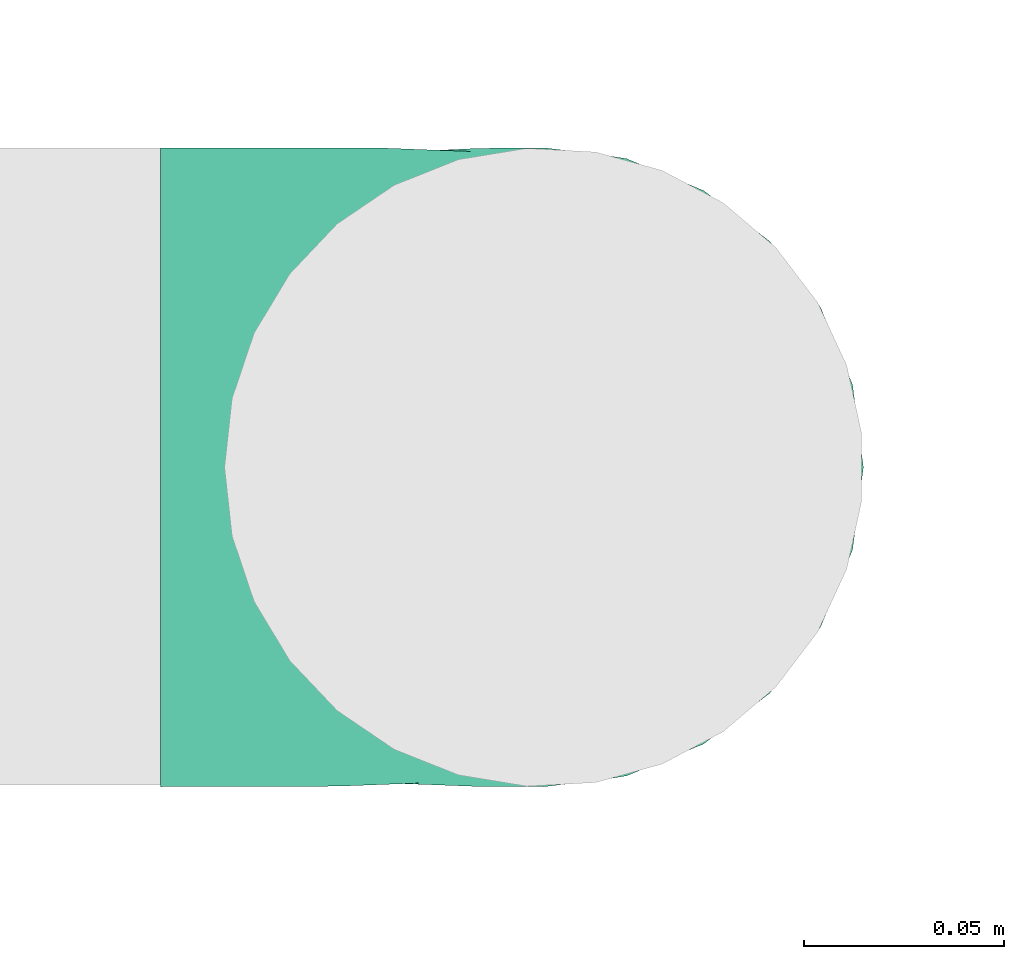
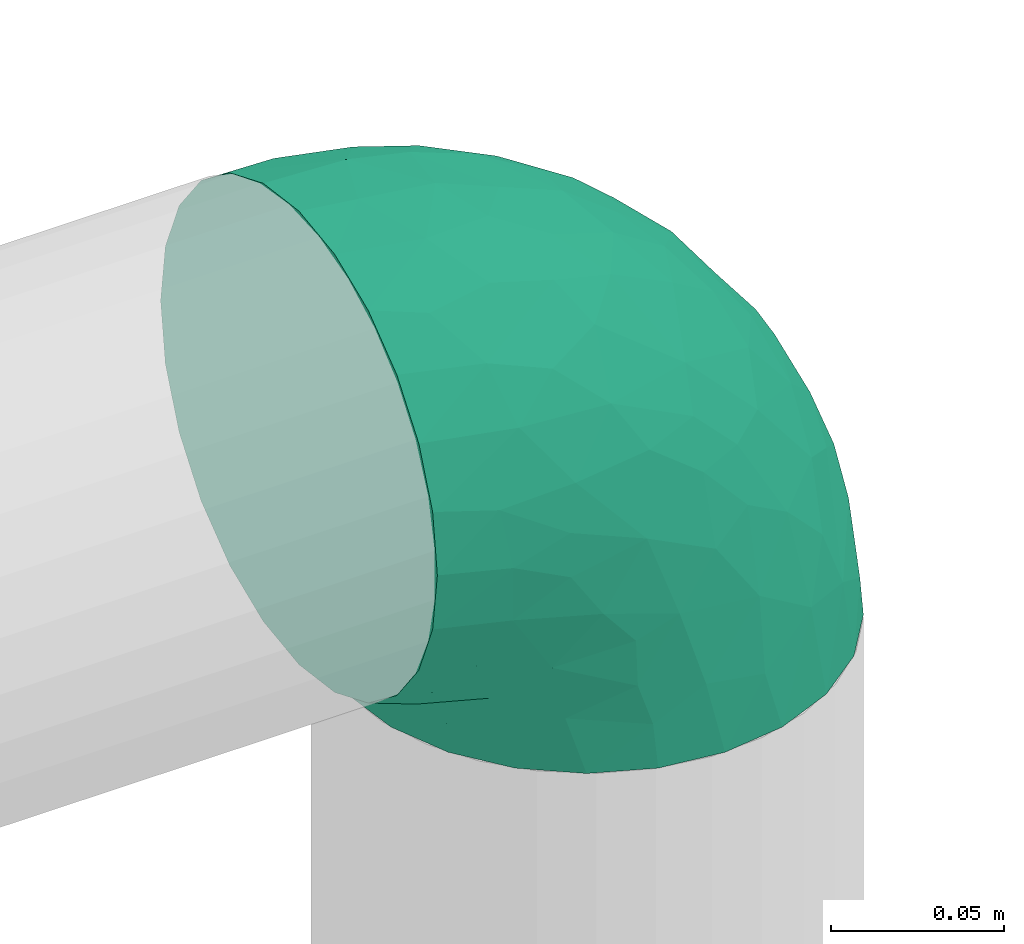
# One storey, part 3 of 12: 1 flow fitting.
"""IFC2X3 building model written with IfcOpenShell, lengths in millimetres."""

from ifc_helpers import new_model, entity, si_unit, converted_unit, derived_unit, direction, frame, origin, place, context, subcontext, project, spatial, faceted_brep, source, transform, mapped, type_object, type_shapes, element, save


model = new_model("IFC2X3")

# Units and contexts
model_context = context("Model", 3, precision=0.01, world=origin(), true_north=direction((6.12303176911189e-17, 1.0)))
body_context = subcontext(model_context, "Body", "Model", "MODEL_VIEW")
ifc_project = project(units=[si_unit("LENGTHUNIT", "METRE", prefix="MILLI"), si_unit("AREAUNIT", "SQUARE_METRE"), si_unit("VOLUMEUNIT", "CUBIC_METRE"), converted_unit("PLANEANGLEUNIT", "DEGREE", entity("IfcRatioMeasure", 0.0174532925199433), si_unit("PLANEANGLEUNIT", "RADIAN"), dimensions=[0, 0, 0, 0, 0, 0, 0]), si_unit("MASSUNIT", "GRAM", prefix="KILO"), derived_unit("MASSDENSITYUNIT", [(si_unit("MASSUNIT", "GRAM", prefix="KILO"), 1), (si_unit("LENGTHUNIT", "METRE"), -3)]), si_unit("TIMEUNIT", "SECOND"), si_unit("FREQUENCYUNIT", "HERTZ"), si_unit("THERMODYNAMICTEMPERATUREUNIT", "DEGREE_CELSIUS"), derived_unit("THERMALTRANSMITTANCEUNIT", [(si_unit("MASSUNIT", "GRAM", prefix="KILO"), 1), (si_unit("THERMODYNAMICTEMPERATUREUNIT", "KELVIN"), -1), (si_unit("TIMEUNIT", "SECOND"), -3)]), derived_unit("VOLUMETRICFLOWRATEUNIT", [(si_unit("LENGTHUNIT", "METRE"), 3), (si_unit("TIMEUNIT", "SECOND"), -1)]), si_unit("ELECTRICCURRENTUNIT", "AMPERE"), si_unit("ELECTRICVOLTAGEUNIT", "VOLT"), si_unit("POWERUNIT", "WATT"), si_unit("FORCEUNIT", "NEWTON", prefix="KILO"), si_unit("ILLUMINANCEUNIT", "LUX"), si_unit("LUMINOUSFLUXUNIT", "LUMEN"), si_unit("LUMINOUSINTENSITYUNIT", "CANDELA"), derived_unit("USERDEFINED", [(si_unit("MASSUNIT", "GRAM", prefix="KILO"), -1), (si_unit("LENGTHUNIT", "METRE"), -2), (si_unit("TIMEUNIT", "SECOND"), 3), (si_unit("LUMINOUSFLUXUNIT", "LUMEN"), 1)]), derived_unit("LINEARVELOCITYUNIT", [(si_unit("LENGTHUNIT", "METRE"), 1), (si_unit("TIMEUNIT", "SECOND"), -1)]), si_unit("PRESSUREUNIT", "PASCAL"), derived_unit("USERDEFINED", [(si_unit("LENGTHUNIT", "METRE"), -2), (si_unit("MASSUNIT", "GRAM", prefix="KILO"), 1), (si_unit("TIMEUNIT", "SECOND"), -2)])], contexts=[model_context])

# Site, building, storey
site_placement = place(None, origin())
site = spatial("IfcSite", under=ifc_project, at=site_placement, CompositionType="ELEMENT")
building_placement = place(site_placement, origin())
building = spatial("IfcBuilding", under=site, at=building_placement, CompositionType="ELEMENT")
storey_placement = place(building_placement, frame((0.0, 0.0, 8000.0)))
storey = spatial("IfcBuildingStorey", under=building, at=storey_placement, Name="02 Level", CompositionType="ELEMENT", Elevation=8000.0)

# Flow fitting
duct_fitting_type = type_object("IfcDuctFittingType", Name="Air_Elbow short_Circ", PredefinedType="NOTDEFINED")
shared_shape = source(origin(), body_context, "Body", "Brep", [
    faceted_brep([(-96.0, 40.0, -69.2820323027551), (-96.0, 20.7055236082018, -77.2740661031254), (-96.0, 0.0, -80.0), (-96.0, -20.7055236082015, -77.2740661031255), (-96.0, -40.0, -69.2820323027552), (-96.0, -56.5685424949237, -56.5685424949239), (-96.0, -69.282032302755, -40.0), (-96.0, -77.2740661031254, -20.7055236082019), (-96.0, -80.0, 0.0), (-96.0, -77.2740661031256, 20.7055236082014), (-96.0, -69.2820323027553, 40.0), (-96.0, -56.568542494924, 56.5685424949236), (-96.0, -40.0, 69.2820323027549), (-96.0, -20.705523608202, 77.2740661031254), (-96.0, 0.0, 80.0), (-96.0, 20.7055236082013, 77.2740661031256), (-96.0, 30.3527618041005, 73.2780492029404), (-96.0, 40.0, 69.2820323027553), (-96.0, 56.5685424949235, 56.5685424949241), (-96.0, 69.2820323027549, 40.0), (-96.0, 77.2740661031253, 20.7055236082021), (-96.0, 80.0, 0.0), (-96.0, 77.2740661031255, -20.7055236082016), (-96.0, 69.2820323027551, -40.0), (-96.0, 56.5685424949239, -56.5685424949238), (0.0, 96.0, -80.0), (-20.7055236082008, 96.0, -77.2740661031254), (-30.3527618041, 96.0, -73.2780492029402), (-40.0, 96.0, -69.2820323027551), (-56.5685424949229, 96.0, -56.5685424949238), (-69.2820323027542, 96.0, -40.0), (-77.2740661031245, 96.0, -20.7055236082016), (-80.0, 96.0, 0.0), (-77.2740661031244, 96.0, 20.7055236082021), (-69.2820323027539, 96.0, 40.0), (-56.5685424949226, 96.0, 56.5685424949241), (-40.0, 96.0, 69.2820323027553), (-20.7055236082004, 96.0, 77.2740661031256), (0.0, 96.0, 80.0), (20.7055236082029, 96.0, 77.2740661031254), (40.0, 96.0, 69.2820323027549), (56.5685424949249, 96.0, 56.5685424949236), (69.2820323027562, 96.0, 40.0), (77.2740661031265, 96.0, 20.7055236082014), (80.0, 96.0, 0.0), (77.2740661031264, 96.0, -20.7055236082019), (69.2820323027559, 96.0, -40.0), (56.5685424949246, 96.0, -56.5685424949239), (40.0, 96.0, -69.2820323027552), (20.7055236082025, 96.0, -77.2740661031255), (-69.6571465232348, 6.28172173912476, 79.9611058756859), (-55.1380888291464, -64.4450584799279, 39.5029426177976), (-78.4902527850466, -65.2482264041437, 44.9229732355936), (-66.7862289407348, -74.1387210661139, 22.9795507758541), (-79.9123689128389, 22.4151301859584, 77.2816866630488), (-75.1250134759213, 46.3506195730757, 68.0011973810265), (-46.2820694578435, -43.7397705581167, 60.5188244193914), (-62.9760666105318, -34.5362195419601, 70.0448030595901), (-67.1316735243184, -51.7530432423058, 58.5204707533666), (-50.4478480619551, -74.0029454268759, 0.0), (-76.2276812833835, -77.3969248578635, 0.0), (-27.189372084162, 68.980536479128, 76.8941402015288), (-6.30632028234235, 70.6421404093778, 79.9513108199466), (-47.7584488981354, -13.6212410427434, 76.3881123659885), (-29.8609237116382, -28.9682345099716, 65.8760199345924), (57.6005967886466, 33.4719572927763, 39.0176496769077), (51.7530435574228, 67.1316742002235, 58.5204705859065), (43.7397637815864, 46.2820598522933, 60.518827155348), (-74.2591571701267, -14.3645886695287, 78.2829835259588), (28.4507934888335, -28.4507934888321, 0.0), (23.3846344985257, -27.9066135199674, 24.7887114209846), (7.8513563843086, -42.4938374080907, 21.3232874317503), (-84.190871651952, 70.905997349447, 41.7100461919055), (24.7272484782103, -2.06889411058577, 53.4325037134459), (-0.0180155578363953, -25.9284255475521, 53.836744023285), (10.21505333872, -32.0754161621096, 38.020212353501), (-64.5619855594544, 27.52018553659, 77.2892967298799), (-41.7574890626937, 15.123136403511, 79.988056483004), (-24.5336756868846, -60.9669573051438, 23.5003835585885), (-29.2239240309769, -65.2117082464685, 0.0), (-8.0, -56.420471066061, 0.0), (-16.4008295437786, 51.3122057461681, 79.8609584412684), (-83.0529092063249, 83.0529092103045, 19.0855009657076), (-84.6862915010143, 84.6862915010152, 0.0), (-82.4185651555764, 62.2587017800419, 53.3339952483838), (-46.3022193149449, 75.902750025661, 67.8445262622594), (-9.5260688639158, -47.7232209131232, 35.4187162694583), (74.1387213421635, 66.7862279048973, 22.9795492840646), (14.3645870599314, 74.259154996167, 78.2829837700474), (34.536215572589, 62.976064096567, 70.0448048426748), (65.2482273833467, 78.4902510979302, 44.9229715327465), (-12.3935655196116, 25.4017250572252, 78.8652642576962), (-25.6317751341749, 1.2640655514879, 76.9124052095498), (69.8186739706361, 42.5625104806759, 16.7980672722629), (64.4450597015273, 55.1380839274934, 39.5029384026545), (60.9669574479924, 24.5336725945725, 23.5003789659965), (77.3969247188647, 76.2276802275763, 0.0), (74.002945426877, 50.4478480619565, 0.0), (-66.5995156060253, 66.5995146556305, 58.6370817132137), (-52.4774893100348, 53.0631556360015, 72.0041598972686), (-76.4857465466113, 78.9385356944492, 38.5867538667356), (-62.2587016209511, 82.4185645906685, 53.3339956492136), (28.9682276847195, 29.8609133580269, 65.8760207540895), (13.6212369177471, 47.7584433090926, 76.3881128402526), (-6.49930484510329, -53.7890406240985, 15.4645725223014), (-33.731289034344, 40.0214486160993, 79.0537019298314), (46.1336936566893, 26.2441492635858, 50.151541479116), (42.4356322774479, -10.225396744416, 0.0), (56.4204710660622, 8.0, 0.0), (50.0005984633279, 1.26038287501495, 17.5763945268078), (-45.4536887619888, -68.8356359385787, 23.6914879663761), (-33.3493864711472, -57.4572215948989, 39.1720709545353), (35.9683398342664, -11.0724559744972, 30.5391080332169), (-26.2441652621668, -46.1336984778153, 50.1515448602929), (36.6749123583047, -17.5982116941791, 14.5644188861001), (65.2117082464696, 29.2239240309784, 0.0), (49.5968730216335, 12.1440064858134, 34.8325942562253), (-47.1533280807863, 29.0746114834461, 78.9127210009486), (-0.981722938535007, 51.3162880079176, 79.4920802366619), (12.4951682569875, 20.0804783439543, 71.2292489374933), (-1.95170750213435, 1.95169859379814, 70.9272590604952), (13.0725391330592, 1.13338064801589, 63.5790506070627), (-1.93327092594732, -13.4823821925323, 63.7412032706882), (-18.9298205951927, -13.0048872663631, 70.6672094580024), (10.2253967444173, -42.4356322774466, 0.0), (-68.9805369123341, 27.1893702897943, -76.8941406355589), (-22.4151342180024, 79.9123577737124, -77.2816862456941), (-27.5201921618733, 64.5619784506715, -77.2892959136582), (-46.3506180288022, 75.1250185023919, -68.0011970559212), (-74.2591561090454, -14.364589592643, -78.2829832920378), (-42.5625109127564, -69.8186736490614, -16.7980693145318), (-66.78622820047, -74.1387209331735, -22.9795507950237), (-70.6421421271429, 6.30631801763141, -79.9513108797024), (-25.401718902627, 12.3935649209934, -78.8652635038296), (-15.1231475192353, 41.7574898106582, -79.9880566497423), (-1.2640784754681, 25.6317655571971, -76.9124065444174), (-78.9385361639639, 76.4857467527193, -38.5867530236755), (-66.5995166501766, 66.5995137008527, -58.6370816545605), (-82.4185656924104, 62.258701559575, -53.3339952529289), (60.9669567069012, 24.5336743104721, -23.5003834743896), (53.7890400497189, 6.49930371043273, -15.4645720709197), (-55.1380878256228, -64.4450583029017, -39.5029424837467), (-24.5336751436549, -60.9669572920351, -23.5003828649414), (-29.8609212227281, -28.9682353164184, -65.8760186412515), (-26.2441631797834, -46.1336980827234, -50.1515441608816), (-46.2820677406335, -43.7397707662098, -60.5188237522514), (74.1387206827049, 66.7862275406284, -22.9795512458422), (-40.0214489824224, 33.7312845774564, -79.0537024061946), (-78.4902524468744, -65.2482264004152, -44.9229731872606), (-75.902751427461, 46.3022186029078, -67.8445263463497), (-70.9059970555813, 84.1908706304995, -41.7100473389448), (-67.1316724627346, -51.7530434014037, -58.5204704180807), (-62.9760652707231, -34.536220162299, -70.044802546446), (-33.4719630839568, -57.6005950429912, -39.0176564793206), (-51.3122062597491, 16.4008248291117, -79.8609586691244), (-6.28171714934502, 69.65712797409, -79.9611061760713), (51.7530427306645, 67.1316703492073, -58.5204706539109), (-83.0529092397056, 83.0529091932979, -19.0855009185769), (68.8356349913375, 45.45368838847, -23.6914905340598), (-62.258701383479, 82.4185638376438, -53.3339962098694), (34.53621889603, 62.9760621802168, -70.0448028055675), (-1.26038544288408, -50.0005998980998, -17.5763953891677), (13.6212385978137, 47.75844096294, -76.3881120677864), (14.3645887716112, 74.2591526334116, -78.2829833202131), (65.2482261461557, 78.4902526871683, -44.9229735979605), (2.068884460932, -24.7272580800759, -53.4325021883878), (25.9284207554091, 0.0180077987247146, -53.8367428868672), (32.0754071702863, -10.2150656939878, -38.0202105656364), (47.723215348146, 9.52606271707191, -35.4187195087105), (27.9066094773716, -23.3846413342612, -24.7887058003424), (42.4938359077841, -7.8513587520169, -21.3232866357369), (28.9682309044935, 29.8609168472814, -65.8760199178674), (64.4450577206072, 55.1380878066959, -39.5029434692504), (-53.063150048133, 52.4774843719861, -72.0041634993662), (43.7397687897612, 46.2820667462245, -60.5188250739327), (-47.7584463040963, -13.6212426330217, -76.3881115880261), (57.4572201066452, 33.3493827160302, -39.1720708806551), (11.0724494499294, -35.9683446288498, -30.5391089716619), (46.1336964749623, 26.2441642243134, -50.1515465265606), (17.5982028158329, -36.6749194460897, -14.5644209948051), (-12.1440097531109, -49.5968729214507, -34.8325978072281), (-29.0746218055845, 47.1533256390974, -78.912719851915), (-51.3162911259858, 0.981717610547608, -79.4920798409907), (-20.0804667507281, -12.4951842966219, -71.2292388196267), (-1.95170139871169, 1.95169735730944, -70.9272563527003), (-1.13337124471279, -13.072540998247, -63.5790448193562), (13.4823844636247, 1.93327501577089, -63.7412039856557), (13.0048800657406, 18.9298191902065, -70.6672121474654)], [[[0, 1, 2, 3, 4, 5, 6, 7, 8, 9, 10, 11, 12, 13, 14, 15, 16, 17, 18, 19, 20, 21, 22, 23, 24]], [[25, 26, 27, 28, 29, 30, 31, 32, 33, 34, 35, 36, 37, 38, 39, 40, 41, 42, 43, 44, 45, 46, 47, 48, 49]], [[15, 14, 50]], [[51, 52, 53]], [[54, 55, 17]], [[56, 57, 58]], [[59, 53, 60]], [[37, 61, 62]], [[63, 57, 64]], [[65, 66, 67]], [[52, 11, 10]], [[58, 57, 12]], [[68, 14, 13]], [[69, 70, 71]], [[72, 20, 19]], [[57, 63, 68]], [[73, 74, 75]], [[76, 50, 77]], [[13, 12, 57]], [[17, 55, 18]], [[17, 16, 15, 54]], [[78, 79, 80]], [[81, 62, 61]], [[21, 82, 83]], [[57, 56, 64]], [[21, 20, 82]], [[84, 72, 19]], [[12, 11, 58]], [[19, 18, 84]], [[36, 85, 61]], [[75, 74, 86]], [[53, 9, 60]], [[53, 10, 9]], [[42, 87, 43]], [[66, 41, 40]], [[88, 89, 39]], [[42, 41, 90]], [[40, 39, 89]], [[91, 77, 92]], [[87, 42, 90]], [[93, 94, 95]], [[89, 66, 40]], [[87, 96, 43]], [[36, 35, 85]], [[93, 97, 87]], [[85, 98, 99]], [[33, 100, 34]], [[82, 100, 33]], [[100, 98, 101]], [[102, 89, 103]], [[83, 82, 32]], [[78, 80, 104]], [[36, 61, 37]], [[61, 85, 99]], [[105, 77, 91]], [[102, 106, 67]], [[35, 34, 101]], [[37, 62, 38]], [[107, 108, 109]], [[110, 51, 53]], [[88, 39, 38]], [[78, 110, 79]], [[59, 79, 110]], [[51, 110, 111]], [[75, 70, 112]], [[111, 86, 113]], [[107, 114, 69]], [[106, 102, 73]], [[115, 93, 95]], [[62, 88, 38]], [[115, 95, 108]], [[116, 95, 65]], [[95, 116, 109]], [[68, 50, 14]], [[76, 77, 117]], [[76, 117, 99]], [[84, 55, 98]], [[101, 85, 35]], [[98, 55, 99]], [[81, 61, 105]], [[62, 118, 88]], [[67, 66, 89]], [[90, 66, 94]], [[52, 58, 11]], [[58, 51, 111]], [[50, 63, 77]], [[92, 77, 63]], [[119, 91, 120]], [[81, 118, 62]], [[120, 121, 119]], [[73, 112, 116]], [[120, 122, 121]], [[123, 122, 120]], [[74, 64, 113]], [[92, 123, 120]], [[74, 113, 86]], [[73, 121, 122]], [[76, 99, 55]], [[61, 99, 105]], [[9, 8, 60]], [[96, 87, 97]], [[96, 44, 43]], [[89, 88, 103]], [[57, 68, 13]], [[50, 68, 63]], [[100, 101, 34]], [[85, 101, 98]], [[55, 84, 18]], [[72, 98, 100]], [[105, 91, 81]], [[118, 91, 103]], [[91, 118, 81]], [[88, 118, 103]], [[98, 72, 84]], [[72, 100, 82]], [[82, 20, 72]], [[32, 82, 33]], [[53, 52, 10]], [[58, 52, 51]], [[66, 90, 41]], [[87, 90, 94]], [[76, 55, 54]], [[15, 50, 54]], [[50, 76, 54]], [[110, 53, 59]], [[111, 110, 78]], [[78, 104, 86]], [[111, 113, 56]], [[78, 86, 111]], [[86, 71, 75]], [[70, 75, 71]], [[73, 75, 112]], [[104, 124, 71]], [[95, 109, 108]], [[70, 114, 112]], [[94, 65, 95]], [[114, 109, 112]], [[69, 114, 70]], [[109, 114, 107]], [[73, 116, 106]], [[112, 109, 116]], [[66, 65, 94]], [[106, 116, 65]], [[97, 93, 115]], [[86, 104, 71]], [[124, 104, 80]], [[124, 69, 71]], [[94, 93, 87]], [[102, 67, 89]], [[65, 67, 106]], [[111, 56, 58]], [[64, 56, 113]], [[77, 105, 117]], [[99, 117, 105]], [[123, 63, 64]], [[91, 92, 120]], [[63, 123, 92]], [[122, 64, 74]], [[64, 122, 123]], [[73, 122, 74]], [[73, 102, 121]], [[119, 121, 102]], [[102, 103, 119]], [[91, 119, 103]], [[0, 125, 1]], [[126, 127, 128]], [[3, 2, 129]], [[130, 59, 131]], [[1, 132, 2]], [[133, 134, 135]], [[136, 137, 138]], [[139, 108, 140]], [[23, 138, 24]], [[130, 141, 142]], [[23, 22, 136]], [[143, 144, 145]], [[146, 46, 45]], [[147, 134, 133]], [[131, 6, 148]], [[0, 24, 149]], [[131, 60, 7]], [[150, 31, 30]], [[151, 4, 152]], [[153, 151, 145]], [[5, 4, 151]], [[4, 3, 152]], [[154, 132, 125]], [[5, 148, 6]], [[26, 25, 155]], [[3, 129, 152]], [[6, 131, 7]], [[48, 47, 156]], [[21, 83, 157]], [[139, 158, 115]], [[32, 31, 157]], [[157, 136, 22]], [[30, 159, 150]], [[49, 48, 160]], [[124, 80, 161]], [[29, 159, 30]], [[28, 27, 26, 126]], [[149, 125, 0]], [[127, 155, 134]], [[160, 162, 163]], [[164, 47, 46]], [[29, 28, 128]], [[165, 166, 167]], [[49, 163, 25]], [[168, 167, 166]], [[1, 125, 132]], [[139, 115, 108]], [[69, 169, 170]], [[162, 160, 171]], [[156, 160, 48]], [[172, 164, 146]], [[149, 137, 173]], [[146, 96, 97]], [[160, 174, 171]], [[143, 152, 175]], [[156, 174, 160]], [[125, 149, 173]], [[126, 128, 28]], [[97, 115, 158]], [[157, 22, 21]], [[158, 172, 146]], [[146, 45, 96]], [[172, 158, 176]], [[167, 169, 177]], [[176, 168, 178]], [[124, 179, 69]], [[144, 143, 165]], [[79, 130, 142]], [[45, 44, 96]], [[79, 142, 80]], [[180, 142, 153]], [[142, 180, 161]], [[163, 155, 25]], [[181, 134, 147]], [[127, 181, 173]], [[159, 128, 137]], [[138, 149, 24]], [[137, 128, 173]], [[154, 125, 147]], [[132, 182, 129]], [[145, 151, 152]], [[148, 151, 141]], [[164, 156, 47]], [[156, 172, 176]], [[155, 162, 134]], [[135, 134, 162]], [[183, 133, 184]], [[154, 182, 132]], [[184, 185, 183]], [[165, 177, 180]], [[184, 186, 185]], [[187, 186, 184]], [[166, 171, 178]], [[135, 187, 184]], [[166, 178, 168]], [[165, 185, 186]], [[127, 173, 128]], [[125, 173, 147]], [[60, 131, 59]], [[60, 8, 7]], [[132, 129, 2]], [[152, 129, 175]], [[160, 163, 49]], [[155, 163, 162]], [[136, 138, 23]], [[149, 138, 137]], [[128, 159, 29]], [[150, 137, 136]], [[147, 133, 154]], [[182, 133, 175]], [[133, 182, 154]], [[129, 182, 175]], [[137, 150, 159]], [[150, 136, 157]], [[32, 157, 83]], [[157, 31, 150]], [[146, 164, 46]], [[156, 164, 172]], [[151, 148, 5]], [[131, 148, 141]], [[127, 126, 155]], [[26, 155, 126]], [[158, 146, 97]], [[176, 158, 139]], [[139, 140, 168]], [[176, 178, 174]], [[139, 168, 176]], [[168, 170, 167]], [[169, 167, 170]], [[165, 167, 177]], [[140, 107, 170]], [[142, 161, 80]], [[169, 179, 177]], [[141, 153, 142]], [[179, 161, 177]], [[69, 179, 169]], [[161, 179, 124]], [[165, 180, 144]], [[177, 161, 180]], [[151, 153, 141]], [[144, 180, 153]], [[59, 130, 79]], [[168, 140, 170]], [[107, 140, 108]], [[107, 69, 170]], [[141, 130, 131]], [[143, 145, 152]], [[153, 145, 144]], [[176, 174, 156]], [[171, 174, 178]], [[173, 181, 147]], [[127, 134, 181]], [[187, 162, 171]], [[133, 135, 184]], [[162, 187, 135]], [[186, 171, 166]], [[171, 186, 187]], [[165, 186, 166]], [[165, 143, 185]], [[183, 185, 143]], [[143, 175, 183]], [[133, 183, 175]]]),
])
type_shapes(duct_fitting_type, [shared_shape])
flow_fitting_placement = place(storey_placement, frame((23618.7604148601, -69795.234231492, 3000.0), z_axis=(0.0, -1.0, 0.0), x_axis=(0.0, 0.0, 1.0)))
element("IfcFlowFitting", 1, at=flow_fitting_placement, inside=storey, type_object=duct_fitting_type, Name="elbow_short_001:Air_Elbow short_Circ", ObjectType="elbow_short_001:Air_Elbow short_Circ", context=body_context, shape_type="MappedRepresentation", body=[
    mapped(shared_shape, transform((0.0, 0.0, 0.0), scale=1.0)),
])

save(model, "model.ifc")
